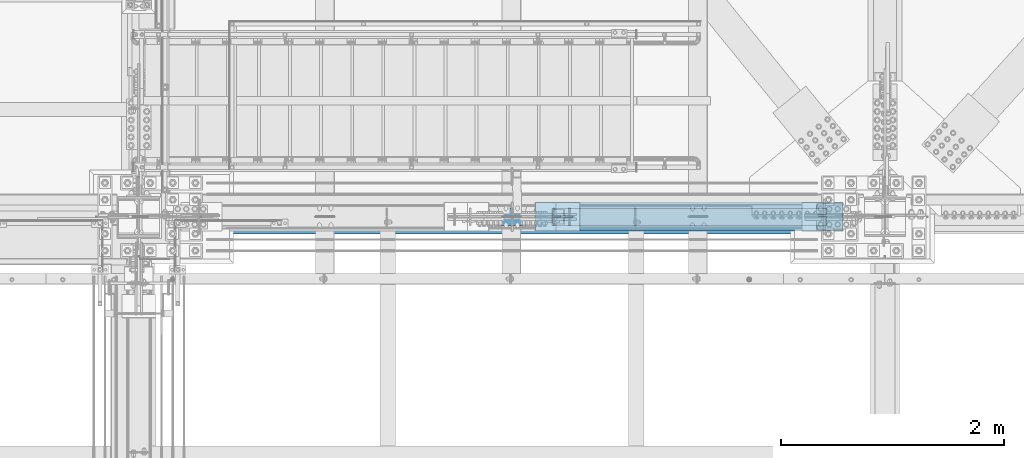
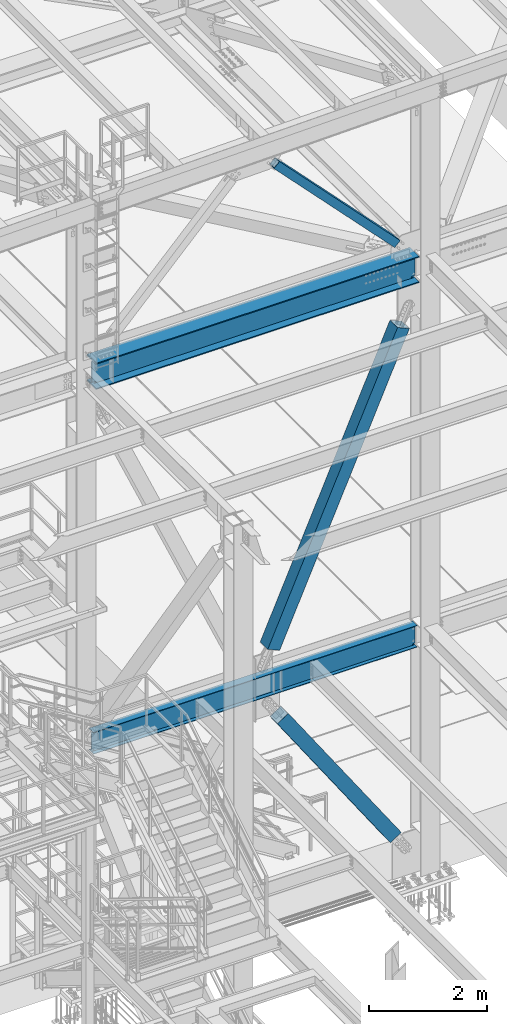
# One storey, part 1788 of 3843: 3 members, 2 beams, 5 elements without a shape of their own.
"""IFC2X3 building model written with IfcOpenShell, lengths in millimetres."""

from ifc_helpers import new_model, si_unit, frame, origin_with_axes, place, context, subcontext, project, spatial, faceted_brep, material, type_object, element, aggregate, save


model = new_model("IFC2X3")

# Units and contexts
model_context = context("Model", 3, precision=1e-05, world=origin_with_axes())
body_context = subcontext(model_context, "Body", "Model", "MODEL_VIEW")
ifc_project = project(units=[si_unit("LENGTHUNIT", "METRE", prefix="MILLI"), si_unit("AREAUNIT", "SQUARE_METRE"), si_unit("VOLUMEUNIT", "CUBIC_METRE"), si_unit("MASSUNIT", "GRAM", prefix="KILO"), si_unit("TIMEUNIT", "SECOND"), si_unit("PLANEANGLEUNIT", "RADIAN"), si_unit("SOLIDANGLEUNIT", "STERADIAN"), si_unit("THERMODYNAMICTEMPERATUREUNIT", "DEGREE_CELSIUS"), si_unit("LUMINOUSINTENSITYUNIT", "LUMEN")], contexts=[model_context])

# Site, building, storey
site_placement = place(None, origin_with_axes())
site = spatial("IfcSite", under=ifc_project, at=site_placement, CompositionType="ELEMENT")
building_placement = place(site_placement, origin_with_axes())
building = spatial("IfcBuilding", under=site, at=building_placement, Name="Undefined", CompositionType="ELEMENT")
storey_placement = place(building_placement, origin_with_axes())
storey = spatial("IfcBuildingStorey", under=building, at=storey_placement, Name="Undefined", CompositionType="ELEMENT", Elevation=0.0)

# Assembly, beam
assembly_1_placement = place(storey_placement, origin_with_axes())
assembly_1 = element("IfcElementAssembly", 1, at=assembly_1_placement, inside=storey, Name="BEAM", AssemblyPlace="NOTDEFINED", PredefinedType="RIGID_FRAME")
ifc_material_1 = material(Name="STEEL/A992")
beam_type_1 = type_object("IfcBeamType", Name="W21X101", PredefinedType="NOTDEFINED")
beam_1_placement = place(assembly_1_placement, frame((55930.8, 25615.8999998765, 42197.3375), z_axis=(0.0, 0.0, 1.0), x_axis=(1.0, 0.0, 0.0)))
beam_1 = element("IfcBeam", 2, at=beam_1_placement, type_object=beam_type_1, material=ifc_material_1, Name="BEAM", ObjectType="W21X101", context=body_context, shape_type="Brep", body=[
    faceted_brep([(6511.925, 6.35000000000946, 215.900000000001), (6504.59265158329, -6.34999999999854, 215.900000000001), (6504.59265158329, -6.34999999999854, -215.900000000001), (6511.925, 6.34999999999854, -215.900000000001), (6500.01039888389, 155.575000000001, 271.462500000001), (6511.925, 155.575000000001, 250.824999999997), (195.262500000001, 155.574999999997, 250.824999999997), (207.177101116094, 155.574999999997, 271.462500000001), (6511.925, 6.34999999999854, 250.824999999997), (195.262500000001, 6.35000000000582, 250.824999999997), (6511.925, -155.575000000001, -271.462500000001), (6500.01038401834, -155.575000000001, -250.824999999997), (207.177115981647, -155.574999999997, -250.824999999997), (195.262500000001, -155.574999999997, -271.462500000001), (6511.925, 155.575000000001, -271.462500000001), (195.262500000001, 155.574999999997, -271.462500000001), (6500.01038401834, 155.575000000001, -250.824999999997), (207.177115981647, 155.574999999997, -250.824999999997), (6500.01038401834, 6.34999999999854, -250.824999999997), (207.177115981647, 6.35000000000582, -250.824999999997), (6430.04956922777, -6.34999999999854, -217.357163726287), (6430.04956922777, 6.34999999999854, -217.357163726287), (6435.11273441852, 6.34999999999854, -215.900000000001), (6435.11273441852, -6.34999999999854, -215.900000000001), (6426.53556119222, -6.34999999999854, -221.282812131343), (6426.53556119222, 6.34999999999854, -221.282812131343), (6425.64587781809, -6.34999999999854, -226.475829690324), (6425.64587781809, 6.34999999999854, -226.475829690324), (6427.65273210119, -6.34999999999854, -231.347328818971), (6427.65273210119, 6.34999999999854, -231.347328818971), (6431.94209456491, -6.34999999999854, -234.406795689014), (6431.94209456491, 6.34999999999854, -234.406795689014), (6477.32699999998, -6.34999999999854, -250.428), (6477.32699999998, 6.34999999999854, -250.428), (6499.78119200916, -6.34999999999854, -250.428), (6499.78119200916, 6.34999999999854, -250.428), (6500.01038401834, -6.34999999999854, -250.824999999997), (207.177115981647, -6.35000000000582, -250.824999999997), (207.406307990826, -6.35000000000582, -250.428), (207.406307990826, 6.35000000000582, -250.428), (229.860500000004, -6.34999999999127, -250.428), (229.860500000004, 6.35000000000582, -250.428), (275.245405435075, -6.34999999999127, -234.406795689014), (275.245405435075, 6.35000000000582, -234.406795689014), (279.534767898796, -6.34999999999127, -231.347328818971), (279.534767898796, 6.35000000000582, -231.347328818971), (281.5416221819, -6.34999999999127, -226.475829690324), (281.5416221819, 6.35000000000582, -226.475829690324), (280.651938807767, -6.34999999999127, -221.282812131343), (280.651938807767, 6.35000000000582, -221.282812131343), (277.137930772215, -6.34999999999127, -217.357163726287), (277.137930772215, 6.35000000000582, -217.357163726287), (272.074765581463, -6.34999999999127, -215.900000000001), (272.074765581463, 6.35000000000582, -215.900000000001), (202.594848416855, -6.34999999999127, -215.900000000001), (195.262500000001, 6.35000000000582, -215.900000000001), (202.594848416855, -6.34999999999127, 215.900000000001), (195.262500000001, 6.35000000000582, 215.900000000001), (272.401765581464, -6.34999999999127, 215.900000000001), (272.401765581464, 6.35000000000582, 215.900000000001), (277.464930772214, -6.34999999999127, 217.357163726287), (277.464930772214, 6.35000000000582, 217.357163726287), (280.978938807766, -6.34999999999127, 221.282812131351), (280.978938807766, 6.35000000000582, 221.282812131351), (281.868622181899, -6.34999999999127, 226.475829690324), (281.868622181899, 6.35000000000582, 226.475829690324), (279.861767898796, -6.34999999999127, 231.347328818971), (279.861767898796, 6.35000000000582, 231.347328818971), (275.572405435074, -6.34999999999127, 234.406795689014), (275.572405435074, 6.35000000000582, 234.406795689014), (230.187500000004, -6.34999999999127, 250.428), (230.187500000004, 6.35000000000582, 250.428), (195.262500000001, -6.35000000000582, 250.428), (195.262500000001, 6.35000000000582, 250.428), (195.262500000001, -6.35000000000582, 250.824999999997), (6511.925, -155.575000000001, 250.824999999997), (6500.01039888389, -155.575000000001, 271.462500000001), (207.177101116094, -155.574999999997, 271.462500000001), (195.262500000001, -155.574999999997, 250.824999999997), (6511.925, -6.34999999999854, 250.824999999997), (6511.925, -6.34999999999854, 250.428), (6511.925, 6.34999999999854, 250.428), (6476.99999999999, -6.34999999999854, 250.428), (6476.99999999999, 6.34999999999854, 250.428), (6431.61509456491, -6.34999999999854, 234.406795689014), (6431.61509456491, 6.34999999999854, 234.406795689014), (6427.32573210119, -6.34999999999854, 231.347328818971), (6427.32573210119, 6.34999999999854, 231.347328818971), (6425.31887781809, -6.34999999999854, 226.475829690324), (6425.31887781809, 6.34999999999854, 226.475829690324), (6426.20856119222, -6.34999999999854, 221.282812131351), (6426.20856119222, 6.34999999999854, 221.282812131351), (6429.72256922777, -6.34999999999854, 217.357163726287), (6429.72256922777, 6.34999999999854, 217.357163726287), (6434.78573441852, -6.34999999999854, 215.900000000001), (6434.78573441852, 6.34999999999854, 215.900000000001)], [[[0, 1, 2, 3]], [[4, 5, 6, 7]], [[5, 8, 9, 6]], [[10, 11, 12, 13]], [[14, 10, 13, 15]], [[16, 14, 15, 17]], [[18, 16, 17, 19]], [[20, 21, 22, 23]], [[24, 25, 21, 20]], [[26, 27, 25, 24]], [[28, 29, 27, 26]], [[30, 31, 29, 28]], [[32, 33, 31, 30]], [[33, 32, 34, 35]], [[10, 14, 16, 18, 35, 34, 36, 11]], [[11, 36, 37, 12]], [[38, 39, 19, 17, 15, 13, 12, 37]], [[40, 41, 39, 38]], [[42, 43, 41, 40]], [[44, 45, 43, 42]], [[46, 47, 45, 44]], [[48, 49, 47, 46]], [[50, 51, 49, 48]], [[52, 53, 51, 50]], [[54, 55, 53, 52]], [[55, 54, 56, 57]], [[58, 59, 57, 56]], [[60, 61, 59, 58]], [[62, 63, 61, 60]], [[64, 65, 63, 62]], [[66, 67, 65, 64]], [[68, 69, 67, 66]], [[70, 71, 69, 68]], [[71, 70, 72, 73]], [[73, 72, 74, 9]], [[75, 76, 77, 78]], [[79, 75, 78, 74]], [[77, 7, 6, 9, 74, 78]], [[76, 4, 7, 77]], [[75, 79, 8, 5, 4, 76]], [[80, 81, 8, 79]], [[82, 83, 81, 80]], [[84, 85, 83, 82]], [[86, 87, 85, 84]], [[88, 89, 87, 86]], [[90, 91, 89, 88]], [[92, 93, 91, 90]], [[94, 95, 93, 92]], [[22, 21, 25, 27, 29, 31, 33, 35, 18, 19, 39, 41, 43, 45, 47, 49, 51, 53, 55, 57, 59, 61, 63, 65, 67, 69, 71, 73, 9, 8, 81, 83, 85, 87, 89, 91, 93, 95, 0, 3]], [[23, 22, 3, 2]], [[94, 92, 90, 88, 86, 84, 82, 80, 79, 74, 72, 70, 68, 66, 64, 62, 60, 58, 56, 54, 52, 50, 48, 46, 44, 42, 40, 38, 37, 36, 34, 32, 30, 28, 26, 24, 20, 23, 2, 1]], [[95, 94, 1, 0]]]),
])
aggregate(assembly_1, [beam_1])

# Assembly, member
assembly_2_placement = place(storey_placement, origin_with_axes())
assembly_2 = element("IfcElementAssembly", 3, at=assembly_2_placement, inside=storey, Name="None", AssemblyPlace="NOTDEFINED", PredefinedType="RIGID_FRAME")
member_type_1 = type_object("IfcMemberType", Name="HSS10X10X1/4", PredefinedType="NOTDEFINED")
member_1_placement = place(assembly_2_placement, frame((61993.3215575745, 25615.9, 30620.9904034749), z_axis=(0.0, 1.0, 0.0), x_axis=(-0.564190505241422, 0.0, 0.825644641353306)))
member_1 = element("IfcMember", 4, at=member_1_placement, type_object=member_type_1, material=ifc_material_1, Name="None", ObjectType="HSS10X10X1/4", context=body_context, shape_type="Brep", body=[
    faceted_brep([(2.00088834390044e-10, 120.650000000089, -120.649999999994), (-2.03726813197136e-10, -120.650000000081, -120.649999999994), (3905.24999997879, -120.649999992253, -120.650000000001), (3905.24999997883, 120.650000006994, -120.650000000001), (-2.03726813197136e-10, -120.650000000081, 120.649999999994), (3905.24999997879, -120.649999992253, 120.650000000001), (2.00088834390044e-10, 120.650000000089, 120.649999999994), (3905.24999997883, 120.650000006994, 120.650000000001), (2.16459739021957e-10, 127.000000000087, -127.0), (2.16459739021957e-10, 127.000000000087, 127.0), (3905.24999997883, 127.000000006985, 127.0), (3905.24999997883, 127.000000006985, -127.0), (-2.14640749618411e-10, -127.00000000008, 127.0), (3905.24999997879, -126.999999992244, 127.0), (-2.14640749618411e-10, -127.00000000008, -127.0), (3905.24999997879, -126.999999992244, -127.0)], [[[0, 1, 2, 3]], [[1, 4, 5, 2]], [[4, 6, 7, 5]], [[6, 0, 3, 7]], [[8, 9, 10, 11]], [[9, 12, 13, 10]], [[12, 14, 15, 13]], [[14, 8, 11, 15]], [[13, 15, 11, 10], [5, 7, 3, 2]], [[14, 12, 9, 8], [6, 4, 1, 0]]]),
])
aggregate(assembly_2, [member_1])

assembly_3_placement = place(storey_placement, origin_with_axes())
assembly_3 = element("IfcElementAssembly", 5, at=assembly_3_placement, inside=storey, Name="None", AssemblyPlace="NOTDEFINED", PredefinedType="RIGID_FRAME")
member_2_placement = place(assembly_3_placement, frame((59610.7380792721, 25615.9, 35326.2149569178), z_axis=(0.0, -1.0, 0.0), x_axis=(0.403080846030053, 0.0, 0.915164374068231)))
member_2 = element("IfcMember", 6, at=member_2_placement, type_object=member_type_1, material=ifc_material_1, Name="None", ObjectType="HSS10X10X1/4", context=body_context, shape_type="Brep", body=[
    faceted_brep([(2.00088834390044e-10, 120.650000000089, -120.649999999994), (-2.03726813197136e-10, -120.650000000081, -120.649999999994), (6280.15037608392, -120.649999997302, -120.650000000001), (6280.15037608382, 120.650000003043, -120.650000000001), (-2.03726813197136e-10, -120.650000000081, 120.649999999994), (6280.15037608392, -120.649999997302, 120.650000000001), (2.00088834390044e-10, 120.650000000089, 120.649999999994), (6280.15037608382, 120.650000003043, 120.650000000001), (2.16459739021957e-10, 127.000000000087, -127.0), (2.16459739021957e-10, 127.000000000087, 127.0), (6280.1503760838, 127.000000003049, 127.0), (6280.1503760838, 127.000000003049, -127.0), (-2.14640749618411e-10, -127.00000000008, 127.0), (6280.15037608392, -126.999999997315, 127.0), (-2.14640749618411e-10, -127.00000000008, -127.0), (6280.15037608392, -126.999999997315, -127.0)], [[[0, 1, 2, 3]], [[1, 4, 5, 2]], [[4, 6, 7, 5]], [[6, 0, 3, 7]], [[8, 9, 10, 11]], [[9, 12, 13, 10]], [[12, 14, 15, 13]], [[14, 8, 11, 15]], [[13, 15, 11, 10], [5, 7, 3, 2]], [[14, 12, 9, 8], [6, 4, 1, 0]]]),
])
aggregate(assembly_3, [member_2])

assembly_4_placement = place(storey_placement, origin_with_axes())
assembly_4 = element("IfcElementAssembly", 7, at=assembly_4_placement, inside=storey, AssemblyPlace="NOTDEFINED", PredefinedType="RIGID_FRAME")
ifc_material_2 = material()
member_type_2 = type_object("IfcMemberType", Name="HSS6X6X3/8", PredefinedType="NOTDEFINED")
member_3_placement = place(assembly_4_placement, frame((59283.5999977443, 25615.9000004153, 45690.7868380796), z_axis=(0.721481345122377, 0.0, 0.692433873117431), x_axis=(0.692433873117435, 0.0, -0.721481345122373)))
member_3 = element("IfcMember", 8, at=member_3_placement, type_object=member_type_2, material=ifc_material_2, ObjectType="HSS6X6X3/8", context=body_context, shape_type="Brep", body=[
    faceted_brep([(601.045314059582, 7.93750015065598, 76.2000000011176), (601.045314059586, 7.93750015065598, 66.6750000011234), (701.05781405931, 7.93750015065598, 66.675000001298), (701.057814059292, 7.93750015065598, 76.2000000013068), (704.09536380371, 7.33329393996974, 66.675000001298), (704.095363803688, 7.33329393996974, 76.2000000013068), (706.670474134971, 5.61266022632481, 66.6750000013126), (706.670474134953, 5.61266022632481, 76.2000000013068), (708.39110784862, 3.03754989505978, 66.6750000013126), (708.391107848602, 3.03754989505978, 76.2000000013213), (701.057814059292, -7.93749984934402, 76.2000000013068), (701.05781405931, -7.93749984934402, 66.675000001298), (601.045314059586, -7.93749984934402, 66.6750000011234), (601.045314059582, -7.93749984934402, 76.2000000011176), (704.095363803688, -7.33329363865778, 76.2000000013068), (704.09536380371, -7.33329363865778, 66.675000001298), (706.670474134953, -5.61265992501285, 76.2000000013068), (706.670474134971, -5.61265992501285, 66.6750000013126), (708.391107848602, -3.03754959374783, 76.2000000013213), (708.39110784862, -3.03754959374783, 66.6750000013126), (708.995314059292, 1.50655978359282e-07, 76.2000000013213), (708.99531405931, 1.50655978359282e-07, 66.6750000013271), (601.045314059582, 7.93750015065598, -66.6749999988679), (601.045314059582, 7.93750015065598, -76.199999998862), (701.057814059575, 7.93750015065598, -76.1999999986874), (701.057814059557, 7.93750015065598, -66.6749999986787), (704.095363803972, 7.33329393996974, -76.1999999986729), (704.095363803954, 7.33329393996974, -66.6749999986787), (706.670474135237, 5.61266022632481, -76.1999999986729), (706.670474135222, 5.61266022632481, -66.6749999986787), (708.391107848885, 3.03754989505978, -76.1999999986729), (708.391107848867, 3.03754989505978, -66.6749999986641), (701.057814059557, -7.93749984934402, -66.6749999986787), (701.057814059575, -7.93749984934402, -76.1999999986874), (601.045314059582, -7.93749984934402, -76.199999998862), (601.045314059582, -7.93749984934402, -66.6749999988679), (704.095363803954, -7.33329363865778, -66.6749999986787), (704.095363803972, -7.33329363865778, -76.1999999986729), (706.670474135222, -5.61265992501285, -66.6749999986787), (706.670474135237, -5.61265992501285, -76.1999999986729), (708.391107848867, -3.03754959374783, -66.6749999986641), (708.391107848885, -3.03754959374783, -76.1999999986729), (708.995314059553, 1.50655978359282e-07, -66.6749999986641), (708.995314059575, 1.50655978359282e-07, -76.1999999986729), (601.045314059586, 66.6750000000029, 66.6750000011234), (601.045314059582, 66.6750000000029, -66.6749999988679), (4001.75746342516, 66.6750000000029, -66.6749999924941), (4001.75746342516, 66.6750000000029, 66.6750000074826), (601.045314059582, 76.1999999999971, -76.199999998862), (4001.75746342517, 76.1999999999971, -76.1999999924883), (4001.75746342517, 20.6374999999971, -76.1999999924883), (3901.74496342337, 20.6374999999971, -76.199999992692), (3898.70741367897, 20.0332937893108, -76.199999992692), (3896.13230334771, 18.3126600756659, -76.199999992692), (3894.41166963406, 15.7375497444009, -76.1999999927066), (3893.80746342337, 12.6999999999971, -76.199999992692), (3894.41166963406, 9.66245025559328, -76.1999999927066), (3896.13230334771, 7.08733992432826, -76.199999992692), (3898.70741367897, 5.36670621068333, -76.199999992692), (3901.74496342337, 4.76249999999709, -76.199999992692), (4001.75746342517, 4.76249999999709, -76.1999999924883), (4001.75746342517, -76.1999999999971, -76.1999999924883), (601.045314059582, -76.1999999999971, -76.199999998862), (4001.75746342516, 20.6374999999971, -66.6749999924941), (3901.74496342335, 20.6374999999971, -66.6749999926833), (3898.70741367896, 20.0332937893108, -66.6749999926833), (3896.13230334769, 18.3126600756659, -66.6749999926978), (3894.41166963404, 15.7375497444009, -66.6749999926978), (3893.80746342336, 12.6999999999971, -66.6749999926978), (3894.41166963404, 9.66245025559328, -66.6749999926978), (3896.13230334769, 7.08733992432826, -66.6749999926978), (3898.70741367896, 5.36670621068333, -66.6749999926833), (3901.74496342335, 4.76249999999709, -66.6749999926833), (4001.75746342516, 4.76249999999709, -66.6749999924941), (601.045314059582, -66.6750000000029, -66.6749999988679), (601.045314059586, -66.6750000000029, 66.6750000011234), (4001.75746342516, -66.6750000000029, 66.6750000074826), (4001.75746342516, -66.6750000000029, -66.6749999924941), (3898.70741367869, 20.0332937893108, 76.2000000072876), (3898.70741367872, 20.0332937893108, 66.6750000072934), (3901.74496342311, 20.6374999999971, 66.6750000072934), (3901.74496342309, 20.6374999999971, 76.2000000072876), (3896.13230334743, 18.3126600756659, 76.2000000072876), (3896.13230334744, 18.3126600756659, 66.6750000072934), (3894.41166963378, 15.7375497444009, 76.2000000072876), (3894.4116696338, 15.7375497444009, 66.6750000072934), (3893.80746342309, 12.6999999999971, 76.2000000072876), (3893.80746342311, 12.6999999999971, 66.6750000072789), (3894.41166963378, 9.66245025559328, 76.2000000072876), (3894.4116696338, 9.66245025559328, 66.6750000072934), (3896.13230334743, 7.08733992432826, 76.2000000072876), (3896.13230334744, 7.08733992432826, 66.6750000072934), (3898.70741367869, 5.36670621068333, 76.2000000072876), (3898.70741367872, 5.36670621068333, 66.6750000072934), (3901.74496342309, 4.76249999999709, 76.2000000072876), (3901.74496342311, 4.76249999999709, 66.6750000072934), (4001.75746342517, 4.76249999999709, 76.2000000074913), (4001.75746342516, 4.76249999999709, 66.6750000074826), (4001.75746342517, -76.1999999999971, 76.2000000074913), (601.045314059582, -76.1999999999971, 76.2000000011176), (4001.75746342516, 20.6374999999971, 66.6750000074826), (4001.75746342517, 20.6374999999971, 76.2000000074913), (4001.75746342517, 76.1999999999971, 76.2000000074913), (601.045314059582, 76.1999999999971, 76.2000000011176)], [[[0, 1, 2, 3]], [[3, 2, 4, 5]], [[5, 4, 6, 7]], [[7, 6, 8, 9]], [[10, 11, 12, 13]], [[14, 15, 11, 10]], [[16, 17, 15, 14]], [[18, 19, 17, 16]], [[20, 21, 19, 18]], [[9, 8, 21, 20]], [[22, 23, 24, 25]], [[25, 24, 26, 27]], [[27, 26, 28, 29]], [[29, 28, 30, 31]], [[32, 33, 34, 35]], [[36, 37, 33, 32]], [[38, 39, 37, 36]], [[40, 41, 39, 38]], [[42, 43, 41, 40]], [[31, 30, 43, 42]], [[44, 45, 46, 47]], [[28, 26, 24, 23, 48, 49, 50, 51, 52, 53, 54, 55, 56, 57, 58, 59, 60, 61, 62, 34, 33, 37, 39, 41, 43, 30]], [[63, 64, 51, 50]], [[65, 52, 51, 64]], [[66, 53, 52, 65]], [[67, 54, 53, 66]], [[68, 55, 54, 67]], [[69, 56, 55, 68]], [[70, 57, 56, 69]], [[71, 58, 57, 70]], [[72, 59, 58, 71]], [[73, 60, 59, 72]], [[74, 75, 76, 77]], [[78, 79, 80, 81]], [[82, 83, 79, 78]], [[84, 85, 83, 82]], [[86, 87, 85, 84]], [[88, 89, 87, 86]], [[90, 91, 89, 88]], [[92, 93, 91, 90]], [[94, 95, 93, 92]], [[96, 97, 95, 94]], [[98, 61, 60, 73, 77, 76, 97, 96]], [[99, 62, 61, 98]], [[75, 74, 35, 34, 62, 99, 13, 12]], [[6, 4, 2, 1, 44, 47, 100, 80, 79, 83, 85, 87, 89, 91, 93, 95, 97, 76, 75, 12, 11, 15, 17, 19, 21, 8]], [[101, 81, 80, 100]], [[47, 46, 63, 50, 49, 102, 101, 100]], [[48, 103, 102, 49]], [[16, 14, 10, 13, 99, 98, 96, 94, 92, 90, 88, 86, 84, 82, 78, 81, 101, 102, 103, 0, 3, 5, 7, 9, 20, 18]], [[103, 48, 23, 22, 45, 44, 1, 0]], [[38, 36, 32, 35, 74, 77, 73, 72, 71, 70, 69, 68, 67, 66, 65, 64, 63, 46, 45, 22, 25, 27, 29, 31, 42, 40]]]),
])
aggregate(assembly_4, [member_3])

# Assembly, beam
assembly_5_placement = place(storey_placement, origin_with_axes())
assembly_5 = element("IfcElementAssembly", 9, at=assembly_5_placement, inside=storey, Name="BEAM", AssemblyPlace="NOTDEFINED", PredefinedType="RIGID_FRAME")
beam_type_2 = type_object("IfcBeamType", Name="W18X35", PredefinedType="NOTDEFINED")
beam_2_placement = place(assembly_5_placement, frame((55930.8, 25615.9, 34585.275), z_axis=(0.0, 0.0, 1.0), x_axis=(1.0, 0.0, 0.0)))
beam_2 = element("IfcBeam", 10, at=beam_2_placement, type_object=beam_type_2, material=ifc_material_1, Name="BEAM", ObjectType="W18X35", context=body_context, shape_type="Brep", body=[
    faceted_brep([(199.845217760565, -3.96875000006185, 185.737500000003), (195.262499999983, 3.96875, 185.737500000003), (195.262499999983, 3.96875, -185.737500000003), (199.845217760565, -3.96875, -185.737500000003), (241.243914427199, -3.96875, -185.737500000003), (241.243914427199, 3.96875, -185.737500000003), (246.218657757083, 3.96875, -187.139843246703), (246.218657757083, -3.96875, -187.139843246703), (249.728561613549, 3.96875, -190.933945604054), (249.728561613549, -3.96875, -190.933945604054), (250.740116250294, 3.96875, -196.002613574703), (250.740116250294, -3.96875, -196.002613574703), (248.955464056751, 3.96875, -200.853351078193), (248.955464056751, -3.96875, -200.853351078193), (244.900105306217, 3.96875, -204.057832812294), (244.900105306217, -3.96875, -204.057832812294), (221.186499999982, 3.96875, -213.915500000003), (221.186499999982, -3.96875, -213.915500000003), (201.907311857787, 3.96875, -213.915500000003), (201.907311857787, -3.96875, -213.915500000003), (6505.50937628439, 3.96875, -214.3125), (6505.50937628439, 76.2000000000007, -214.3125), (201.678123715588, 76.2000000000007, -214.3125), (201.678123715588, 3.96875, -214.3125), (6511.925, 76.2000000000007, -225.425000000003), (195.262499999983, 76.2000000000007, -225.425000000003), (6511.925, -76.2000000000007, -225.425000000003), (195.262499999983, -76.2000000000007, -225.425000000003), (6505.50937628439, -76.2000000000007, -214.3125), (201.678123715588, -76.2000000000007, -214.3125), (201.678123715588, -3.96875, -214.3125), (6505.50937628439, -3.96875, -214.3125), (6505.28018814219, 3.96875, -213.915500000003), (6505.28018814219, -3.96875, -213.915500000003), (6486.001, 3.96875, -213.915500000003), (6486.001, -3.96875, -213.915500000003), (6462.28739469377, 3.96875, -204.057832812294), (6462.28739469377, -3.96875, -204.057832812294), (6458.23203594323, 3.96875, -200.853351078193), (6458.23203594323, -3.96875, -200.853351078193), (6456.44738374968, 3.96875, -196.002613574703), (6456.44738374968, -3.96875, -196.002613574703), (6457.45893838643, 3.96875, -190.933945604054), (6457.45893838643, -3.96875, -190.933945604054), (6460.9688422429, 3.96875, -187.139843246703), (6460.9688422429, -3.96875, -187.139843246703), (6465.94358557278, 3.96875, -185.737500000003), (6465.94358557278, -3.96875, -185.737500000003), (6511.925, 3.96875, -185.737500000003), (6507.34228223941, -3.96875, -185.737500000003), (6511.92499999999, 3.96874999998909, 185.737500000003), (6507.34228223941, -3.96875, 185.737500000003), (6466.46758557278, 3.96875, 185.737500000003), (6466.46758557278, -3.96875, 185.737500000003), (6461.4928422429, 3.96875, 187.139843246703), (6461.4928422429, -3.96875, 187.139843246703), (6457.98293838643, 3.96875, 190.933945604054), (6457.98293838643, -3.96875, 190.933945604054), (6456.97138374968, 3.96875, 196.002613574696), (6456.97138374968, -3.96875, 196.002613574696), (6458.75603594322, 3.96875, 200.853351078193), (6458.75603594322, -3.96875, 200.853351078193), (6462.81139469377, 3.96875, 204.057832812294), (6462.81139469377, -3.96875, 204.057832812294), (6486.52499999999, 3.96875, 213.915500000003), (6486.52499999999, -3.96875, 213.915500000003), (6511.925, 3.96875, 213.915500000003), (6511.925, -3.96875, 213.915500000003), (6511.925, 3.96875, 214.3125), (6511.925, -3.96875, 214.3125), (6511.925, -76.2000000000007, 214.3125), (6511.925, 76.2000000000007, 214.3125), (6505.50940229867, 76.2000000000007, 225.425000000003), (6505.50940229867, -76.2000000000007, 225.425000000003), (195.262499999983, 3.96875, 214.3125), (195.262499999983, 76.2000000000007, 214.3125), (201.678097701311, 76.2000000000007, 225.425000000003), (201.678097701311, -76.2000000000007, 225.425000000003), (195.262499999983, -76.2000000000007, 214.3125), (195.262499999983, -3.96875, 214.3125), (195.262499999983, 3.96875, 213.915500000003), (195.262499999983, -3.96875, 213.915500000003), (220.662499999984, 3.96875, 213.915500000003), (220.662499999984, -3.96875, 213.915500000003), (244.376105306212, 3.96875, 204.057832812294), (244.376105306212, -3.96875, 204.057832812294), (248.431464056754, 3.96875, 200.853351078193), (248.431464056754, -3.96875, 200.853351078193), (250.216116250296, 3.96875, 196.002613574696), (250.216116250296, -3.96875, 196.002613574696), (249.204561613551, 3.96875, 190.933945604054), (249.204561613551, -3.96875, 190.933945604054), (245.694657757078, 3.96875, 187.139843246703), (245.694657757078, -3.96875, 187.139843246703), (240.719914427202, 3.96875, 185.737500000003), (240.719914427202, -3.96875, 185.737500000003)], [[[0, 1, 2, 3]], [[4, 5, 6, 7]], [[7, 6, 8, 9]], [[9, 8, 10, 11]], [[11, 10, 12, 13]], [[13, 12, 14, 15]], [[15, 14, 16, 17]], [[17, 16, 18, 19]], [[20, 21, 22, 23]], [[21, 24, 25, 22]], [[24, 26, 27, 25]], [[26, 28, 29, 27]], [[19, 18, 23, 22, 25, 27, 29, 30]], [[28, 31, 30, 29]], [[26, 24, 21, 20, 32, 33, 31, 28]], [[34, 35, 33, 32]], [[35, 34, 36, 37]], [[37, 36, 38, 39]], [[39, 38, 40, 41]], [[41, 40, 42, 43]], [[43, 42, 44, 45]], [[45, 44, 46, 47]], [[47, 46, 48, 49]], [[50, 51, 49, 48]], [[52, 53, 51, 50]], [[53, 52, 54, 55]], [[55, 54, 56, 57]], [[57, 56, 58, 59]], [[59, 58, 60, 61]], [[61, 60, 62, 63]], [[63, 62, 64, 65]], [[65, 64, 66, 67]], [[67, 66, 68, 69]], [[70, 69, 68, 71, 72, 73]], [[71, 68, 74, 75]], [[72, 71, 75, 76]], [[73, 72, 76, 77]], [[70, 73, 77, 78]], [[69, 70, 78, 79]], [[77, 76, 75, 74, 79, 78]], [[80, 81, 79, 74]], [[82, 83, 81, 80]], [[83, 82, 84, 85]], [[85, 84, 86, 87]], [[87, 86, 88, 89]], [[89, 88, 90, 91]], [[91, 90, 92, 93]], [[93, 92, 94, 95]], [[4, 7, 9, 11, 13, 15, 17, 19, 30, 31, 33, 35, 37, 39, 41, 43, 45, 47, 49, 51, 53, 55, 57, 59, 61, 63, 65, 67, 69, 79, 81, 83, 85, 87, 89, 91, 93, 95, 0, 3]], [[5, 4, 3, 2]], [[94, 92, 90, 88, 86, 84, 82, 80, 74, 68, 66, 64, 62, 60, 58, 56, 54, 52, 50, 48, 46, 44, 42, 40, 38, 36, 34, 32, 20, 23, 18, 16, 14, 12, 10, 8, 6, 5, 2, 1]], [[95, 94, 1, 0]]]),
])
aggregate(assembly_5, [beam_2])

save(model, "model.ifc")
